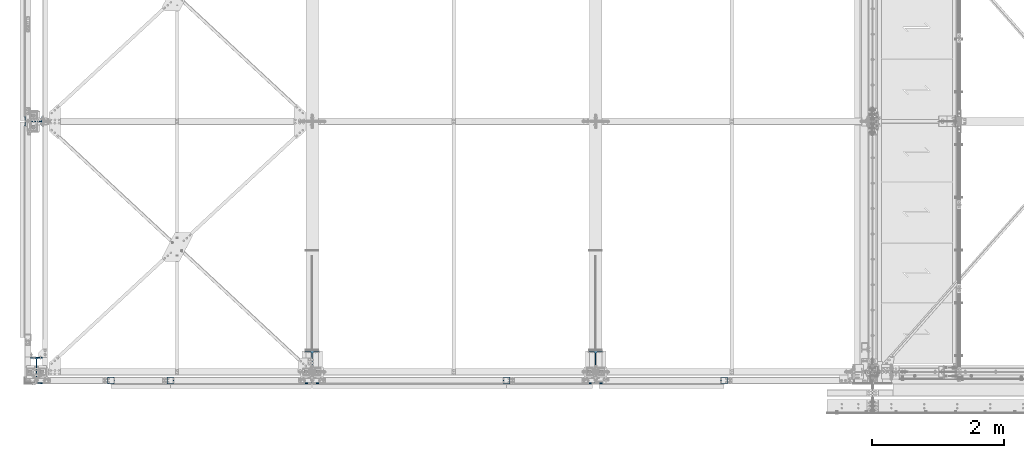
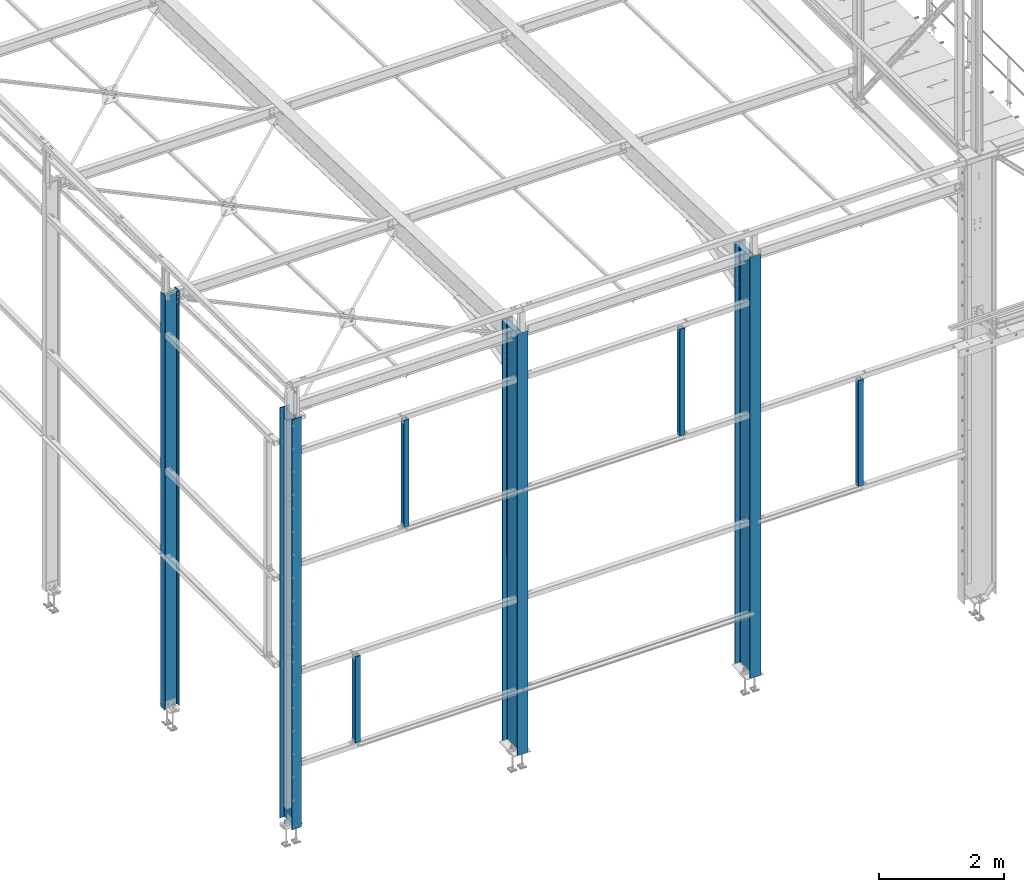
# One storey, part 1 of 496: 8 columns, 8 elements without a shape of their own.
"""IFC2X3 building model written with IfcOpenShell, lengths in millimetres."""

from ifc_helpers import new_model, si_unit, frame, origin_with_axes, origin_2d_with_axis, place, context, subcontext, project, spatial, hollow_rectangle, i_section, extrude, clip, halfspace, material, type_object, element, aggregate, save


model = new_model("IFC2X3")

# Units and contexts
model_context = context("Model", 3, precision=1e-05, world=origin_with_axes())
body_context = subcontext(model_context, "Body", "Model", "MODEL_VIEW")
ifc_project = project(units=[si_unit("LENGTHUNIT", "METRE", prefix="MILLI"), si_unit("AREAUNIT", "SQUARE_METRE"), si_unit("VOLUMEUNIT", "CUBIC_METRE"), si_unit("MASSUNIT", "GRAM", prefix="KILO"), si_unit("TIMEUNIT", "SECOND"), si_unit("PLANEANGLEUNIT", "RADIAN"), si_unit("SOLIDANGLEUNIT", "STERADIAN"), si_unit("THERMODYNAMICTEMPERATUREUNIT", "DEGREE_CELSIUS"), si_unit("LUMINOUSINTENSITYUNIT", "LUMEN")], contexts=[model_context])

# Site, building, storey
site_placement = place(None, origin_with_axes())
site = spatial("IfcSite", under=ifc_project, at=site_placement, CompositionType="ELEMENT")
building_placement = place(site_placement, origin_with_axes())
building = spatial("IfcBuilding", under=site, at=building_placement, Name="Undefined", CompositionType="ELEMENT")
storey_placement = place(building_placement, origin_with_axes())
storey = spatial("IfcBuildingStorey", under=building, at=storey_placement, Name="Undefined", CompositionType="ELEMENT", Elevation=0.0)

# Assembly, column
assembly_1_placement = place(storey_placement, origin_with_axes())
assembly_1 = element("IfcElementAssembly", 1, at=assembly_1_placement, inside=storey, Name="MONTANT", AssemblyPlace="NOTDEFINED", PredefinedType="NOTDEFINED")
ifc_material_1 = material(Name="Undefined/S235-E24")
column_type_1 = type_object("IfcColumnType", PredefinedType="NOTDEFINED")
column_1_placement = place(assembly_1_placement, frame((2029.99476747419, -129.999947446899, 5004.99999999971), z_axis=(0.0, 0.0, 1.0), x_axis=(0.0, 1.0, 0.0)))
column_1 = element("IfcColumn", 2, at=column_1_placement, type_object=column_type_1, material=ifc_material_1, Name="MONTANT", context=body_context, shape_type="SweptSolid", body=[
    extrude(hollow_rectangle(XDim=100.0, YDim=100.0, WallThickness=4.0, InnerFilletRadius=4.0, OuterFilletRadius=8.0, at=origin_2d_with_axis()), frame((0.0, 0.0, 2090.0), z_axis=(0.0, 0.0, -1.0), x_axis=(0.0, 1.0, 0.0)), (0.0, 0.0, 1.0), 2090.0),
])
aggregate(assembly_1, [column_1])

assembly_2_placement = place(storey_placement, origin_with_axes())
assembly_2 = element("IfcElementAssembly", 3, at=assembly_2_placement, inside=storey, Name="MONTANT", AssemblyPlace="NOTDEFINED", PredefinedType="NOTDEFINED")
column_2_placement = place(assembly_2_placement, frame((10429.999999969, -129.99992309536, 2864.99999999972), z_axis=(0.0, 0.0, 1.0), x_axis=(0.0, 1.0, 0.0)))
column_2 = element("IfcColumn", 4, at=column_2_placement, type_object=column_type_1, material=ifc_material_1, Name="MONTANT", context=body_context, shape_type="SweptSolid", body=[
    extrude(hollow_rectangle(XDim=100.0, YDim=100.0, WallThickness=4.0, InnerFilletRadius=4.0, OuterFilletRadius=8.0, at=origin_2d_with_axis()), frame((0.0, 0.0, 2070.0), z_axis=(0.0, 0.0, -1.0), x_axis=(0.0, 1.0, 0.0)), (0.0, 0.0, 1.0), 2070.0),
])
aggregate(assembly_2, [column_2])

assembly_3_placement = place(storey_placement, origin_with_axes())
assembly_3 = element("IfcElementAssembly", 5, at=assembly_3_placement, inside=storey, Name="MONTANT", AssemblyPlace="NOTDEFINED", PredefinedType="NOTDEFINED")
column_3_placement = place(assembly_3_placement, frame((1130.0, -129.999990985576, 1104.99999999971), z_axis=(0.0, 0.0, 1.0), x_axis=(0.0, 1.0, 0.0)))
column_3 = element("IfcColumn", 6, at=column_3_placement, type_object=column_type_1, material=ifc_material_1, Name="MONTANT", context=body_context, shape_type="SweptSolid", body=[
    extrude(hollow_rectangle(XDim=100.0, YDim=100.0, WallThickness=4.0, InnerFilletRadius=4.0, OuterFilletRadius=8.0, at=origin_2d_with_axis()), frame((0.0, 0.0, 1690.0), z_axis=(0.0, 0.0, -1.0), x_axis=(0.0, 1.0, 0.0)), (0.0, 0.0, 1.0), 1690.0),
])
aggregate(assembly_3, [column_3])

assembly_4_placement = place(storey_placement, origin_with_axes())
assembly_4 = element("IfcElementAssembly", 7, at=assembly_4_placement, inside=storey, Name="MONTANT", AssemblyPlace="NOTDEFINED", PredefinedType="NOTDEFINED")
column_4_placement = place(assembly_4_placement, frame((7130.0025831881, -129.999947446899, 5004.99999999971), z_axis=(0.0, 0.0, 1.0), x_axis=(0.0, 1.0, 0.0)))
column_4 = element("IfcColumn", 8, at=column_4_placement, type_object=column_type_1, material=ifc_material_1, Name="MONTANT", context=body_context, shape_type="SweptSolid", body=[
    extrude(hollow_rectangle(XDim=100.0, YDim=100.0, WallThickness=4.0, InnerFilletRadius=4.0, OuterFilletRadius=8.0, at=origin_2d_with_axis()), frame((0.0, 0.0, 2090.0), z_axis=(0.0, 0.0, -1.0), x_axis=(0.0, 1.0, 0.0)), (0.0, 0.0, 1.0), 2090.0),
])
aggregate(assembly_4, [column_4])

assembly_5_placement = place(storey_placement, origin_with_axes())
assembly_5 = element("IfcElementAssembly", 9, at=assembly_5_placement, inside=storey, Name="POTEAU", AssemblyPlace="NOTDEFINED", PredefinedType="NOTDEFINED")
ifc_material_2 = material(Name="Undefined/S275-E28")
column_type_2 = type_object("IfcColumnType", Name="IPE500", PredefinedType="NOTDEFINED")
column_5_placement = place(assembly_5_placement, frame((8479.99715044471, 70.0, -185.0), z_axis=(0.0, 0.0, 1.0), x_axis=(0.0, 1.0, 0.0)))
column_5 = element("IfcColumn", 10, at=column_5_placement, type_object=column_type_2, material=ifc_material_2, Name="POTEAU", ObjectType="IPE500", context=body_context, shape_type="Clipping", body=[
    clip(extrude(i_section(OverallWidth=200.0, OverallDepth=500.0, WebThickness=10.19999981, FlangeThickness=16.0, FilletRadius=21.0, at=origin_2d_with_axis()), frame((0.0, 0.0, 8234.99544952447), z_axis=(0.0, 0.0, -1.0), x_axis=(0.0, 1.0, 0.0)), (0.0, 0.0, 1.0), 8235.0), halfspace(frame((-250.0, 99.9999982502231, 8230.65175644266), z_axis=(0.0314107590115582, 0.0, 0.999506560367824), x_axis=(0.999506560367824, 0.0, -0.0314107590115582)), False)),
])
aggregate(assembly_5, [column_5])

assembly_6_placement = place(storey_placement, origin_with_axes())
assembly_6 = element("IfcElementAssembly", 11, at=assembly_6_placement, inside=storey, Name="POTEAU", AssemblyPlace="NOTDEFINED", PredefinedType="NOTDEFINED")
column_6_placement = place(assembly_6_placement, frame((4179.99715044471, 70.0, -185.0), z_axis=(0.0, 0.0, 1.0), x_axis=(0.0, 1.0, 0.0)))
column_6 = element("IfcColumn", 12, at=column_6_placement, type_object=column_type_2, material=ifc_material_2, Name="POTEAU", ObjectType="IPE500", context=body_context, shape_type="Clipping", body=[
    clip(extrude(i_section(OverallWidth=200.0, OverallDepth=500.0, WebThickness=10.19999981, FlangeThickness=16.0, FilletRadius=21.0, at=origin_2d_with_axis()), frame((0.0, 0.0, 8234.99544952447), z_axis=(0.0, 0.0, -1.0), x_axis=(0.0, 1.0, 0.0)), (0.0, 0.0, 1.0), 8235.0), halfspace(frame((-250.0, 99.9999982502231, 8230.65175644266), z_axis=(0.0314107590115582, 0.0, 0.999506560367824), x_axis=(0.999506560367824, 0.0, -0.0314107590115582)), False)),
])
aggregate(assembly_6, [column_6])

assembly_7_placement = place(storey_placement, origin_with_axes())
assembly_7 = element("IfcElementAssembly", 13, at=assembly_7_placement, inside=storey, Name="POTEAU", AssemblyPlace="NOTDEFINED", PredefinedType="NOTDEFINED")
column_type_3 = type_object("IfcColumnType", Name="IPE270", PredefinedType="NOTDEFINED")
column_7_placement = place(assembly_7_placement, frame((-45.0, 3800.0, -180.0), z_axis=(0.0, 0.0, 1.0), x_axis=(-1.0, 0.0, 0.0)))
column_7 = element("IfcColumn", 14, at=column_7_placement, type_object=column_type_3, material=ifc_material_2, Name="POTEAU", ObjectType="IPE270", context=body_context, shape_type="SweptSolid", body=[
    extrude(i_section(OverallWidth=135.0, OverallDepth=270.0, WebThickness=6.599999905, FlangeThickness=10.19999981, FilletRadius=15.0, at=origin_2d_with_axis()), frame((0.0, 0.0, 8104.99916593884), z_axis=(0.0, 0.0, -1.0), x_axis=(0.0, 1.0, 0.0)), (0.0, 0.0, 1.0), 8105.0),
])
aggregate(assembly_7, [column_7])

assembly_8_placement = place(storey_placement, origin_with_axes())
assembly_8 = element("IfcElementAssembly", 15, at=assembly_8_placement, inside=storey, Name="POTEAU", AssemblyPlace="NOTDEFINED", PredefinedType="NOTDEFINED")
column_type_4 = type_object("IfcColumnType", Name="IPE400", PredefinedType="NOTDEFINED")
column_8_placement = place(assembly_8_placement, frame((0.0, 20.0000000000027, -180.0), z_axis=(0.0, 0.0, 1.0), x_axis=(0.0, 1.0, 0.0)))
column_8 = element("IfcColumn", 16, at=column_8_placement, type_object=column_type_4, material=ifc_material_2, Name="POTEAU", ObjectType="IPE400", context=body_context, shape_type="SweptSolid", body=[
    extrude(i_section(OverallWidth=180.0, OverallDepth=400.0, WebThickness=8.600000381, FlangeThickness=13.5, FilletRadius=21.0, at=origin_2d_with_axis()), frame((0.0, 0.0, 8019.99544952392), z_axis=(0.0, 0.0, -1.0), x_axis=(0.0, 1.0, 0.0)), (0.0, 0.0, 1.0), 8020.0),
])
aggregate(assembly_8, [column_8])

save(model, "model.ifc")
